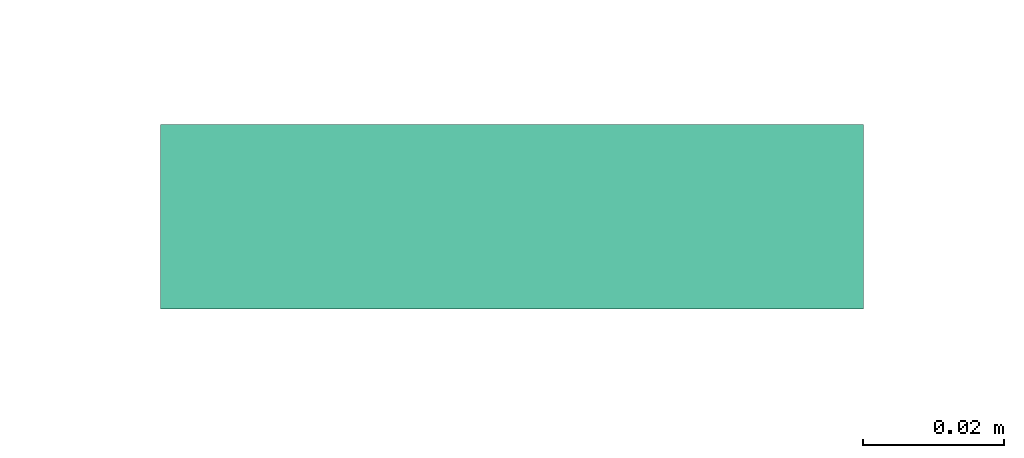
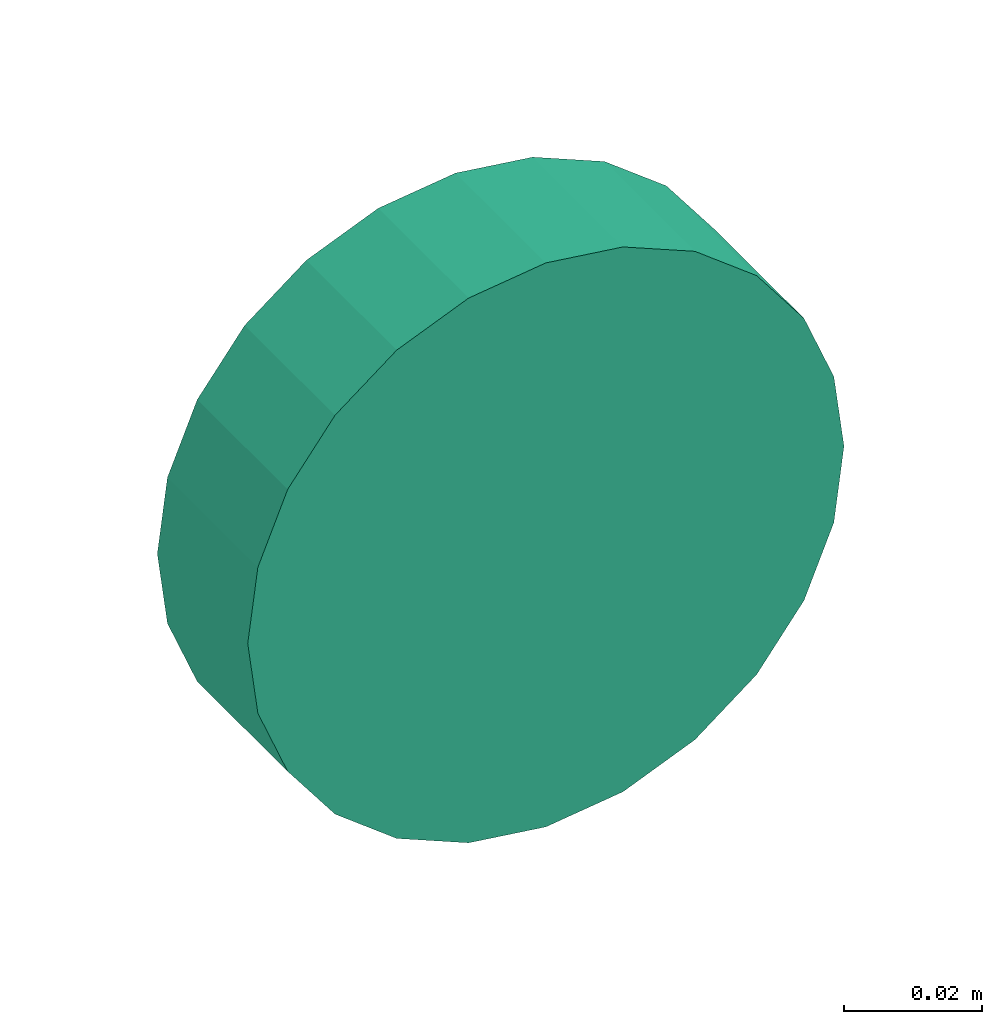
# One storey, part 30 of 32: 1 flow fitting.
"""IFC2X3 building model written with IfcOpenShell, lengths in millimetres."""

from ifc_helpers import new_model, entity, si_unit, converted_unit, derived_unit, direction, frame, origin, place, context, subcontext, project, spatial, faceted_brep, source, transform, mapped, material, type_object, type_shapes, element, save


model = new_model("IFC2X3")

# Units and contexts
model_context = context("Model", 3, precision=0.01, world=origin(), true_north=direction((6.12303176911189e-17, 1.0)))
body_context = subcontext(model_context, "Body", "Model", "MODEL_VIEW")
ifc_project = project(units=[si_unit("LENGTHUNIT", "METRE", prefix="MILLI"), si_unit("AREAUNIT", "SQUARE_METRE"), si_unit("VOLUMEUNIT", "CUBIC_METRE"), converted_unit("PLANEANGLEUNIT", "DEGREE", entity("IfcRatioMeasure", 0.0174532925199433), si_unit("PLANEANGLEUNIT", "RADIAN"), dimensions=[0, 0, 0, 0, 0, 0, 0]), si_unit("MASSUNIT", "GRAM", prefix="KILO"), derived_unit("MASSDENSITYUNIT", [(si_unit("MASSUNIT", "GRAM", prefix="KILO"), 1), (si_unit("LENGTHUNIT", "METRE"), -3)]), derived_unit("MOMENTOFINERTIAUNIT", [(si_unit("LENGTHUNIT", "METRE"), 4)]), si_unit("TIMEUNIT", "SECOND"), si_unit("FREQUENCYUNIT", "HERTZ"), si_unit("THERMODYNAMICTEMPERATUREUNIT", "DEGREE_CELSIUS"), derived_unit("THERMALTRANSMITTANCEUNIT", [(si_unit("MASSUNIT", "GRAM", prefix="KILO"), 1), (si_unit("THERMODYNAMICTEMPERATUREUNIT", "KELVIN"), -1), (si_unit("TIMEUNIT", "SECOND"), -3)]), derived_unit("VOLUMETRICFLOWRATEUNIT", [(si_unit("LENGTHUNIT", "METRE"), 3), (si_unit("TIMEUNIT", "SECOND"), -1)]), derived_unit("MASSFLOWRATEUNIT", [(si_unit("MASSUNIT", "GRAM", prefix="KILO"), 1), (si_unit("TIMEUNIT", "SECOND"), -1)]), derived_unit("ROTATIONALFREQUENCYUNIT", [(si_unit("TIMEUNIT", "SECOND"), -1)]), si_unit("ELECTRICCURRENTUNIT", "AMPERE"), si_unit("ELECTRICVOLTAGEUNIT", "VOLT"), si_unit("POWERUNIT", "WATT"), si_unit("FORCEUNIT", "NEWTON", prefix="KILO"), si_unit("ILLUMINANCEUNIT", "LUX"), si_unit("LUMINOUSFLUXUNIT", "LUMEN"), si_unit("LUMINOUSINTENSITYUNIT", "CANDELA"), derived_unit("USERDEFINED", [(si_unit("MASSUNIT", "GRAM", prefix="KILO"), -1), (si_unit("LENGTHUNIT", "METRE"), -2), (si_unit("TIMEUNIT", "SECOND"), 3), (si_unit("LUMINOUSFLUXUNIT", "LUMEN"), 1)]), derived_unit("LINEARVELOCITYUNIT", [(si_unit("LENGTHUNIT", "METRE"), 1), (si_unit("TIMEUNIT", "SECOND"), -1)]), si_unit("PRESSUREUNIT", "PASCAL"), derived_unit("USERDEFINED", [(si_unit("LENGTHUNIT", "METRE"), -2), (si_unit("MASSUNIT", "GRAM", prefix="KILO"), 1), (si_unit("TIMEUNIT", "SECOND"), -2)]), derived_unit("LINEARFORCEUNIT", [(si_unit("MASSUNIT", "GRAM", prefix="KILO"), 1), (si_unit("LENGTHUNIT", "METRE"), 1), (si_unit("TIMEUNIT", "SECOND"), -2), (si_unit("LENGTHUNIT", "METRE"), -1)]), derived_unit("PLANARFORCEUNIT", [(si_unit("MASSUNIT", "GRAM", prefix="KILO"), 1), (si_unit("LENGTHUNIT", "METRE"), 1), (si_unit("TIMEUNIT", "SECOND"), -2), (si_unit("LENGTHUNIT", "METRE"), -2)])], contexts=[model_context])

# Site, building, storey
site_placement = place(None, origin())
site = spatial("IfcSite", under=ifc_project, at=site_placement, CompositionType="ELEMENT")
building_placement = place(site_placement, origin())
building = spatial("IfcBuilding", under=site, at=building_placement, CompositionType="ELEMENT")
storey_placement = place(building_placement, frame((0.0, 0.0, 8100.0)))
storey = spatial("IfcBuildingStorey", under=building, at=storey_placement, CompositionType="ELEMENT", Elevation=8100.0)

# Flow fitting
ifc_material = material()
duct_fitting_type = type_object("IfcDuctFittingType", PredefinedType="NOTDEFINED", material=ifc_material)
shared_shape = source(origin(), body_context, "Body", "Brep", [
    faceted_brep([(20.08, 12.94, -48.3), (20.08, 25.0, -43.3), (20.08, 35.36, -35.36), (20.08, 43.3, -25.0), (20.08, 48.3, -12.94), (20.08, 50.0, 0.0), (20.08, 48.3, 12.94), (20.08, 43.3, 25.0), (20.08, 35.36, 35.36), (20.08, 25.0, 43.3), (20.08, 12.94, 48.3), (20.08, 0.0, 50.0), (20.08, -12.94, 48.3), (20.08, -25.0, 43.3), (20.08, -35.36, 35.36), (20.08, -43.3, 25.0), (20.08, -48.3, 12.94), (20.08, -50.0, 0.0), (20.08, -48.3, -12.94), (20.08, -43.3, -25.0), (20.08, -35.36, -35.36), (20.08, -25.0, -43.3), (20.08, -12.94, -48.3), (20.08, 0.0, -50.0), (0.0, 0.0, 50.0), (0.0, 12.94, 48.3), (-6.18, 12.94, 48.3), (-6.18, 0.0, 50.0), (0.0, 25.0, 43.3), (-6.18, 25.0, 43.3), (0.0, 35.36, 35.36), (-6.18, 35.36, 35.36), (0.0, 43.3, 25.0), (0.0, 48.3, 12.94), (-6.18, 48.3, 12.94), (-6.18, 43.3, 25.0), (0.0, 50.0, 0.0), (-6.18, 50.0, 0.0), (0.0, 48.3, -12.94), (-6.18, 48.3, -12.94), (0.0, 43.3, -25.0), (-6.18, 43.3, -25.0), (0.0, 35.36, -35.36), (-6.18, 35.36, -35.36), (0.0, 25.0, -43.3), (0.0, 12.94, -48.3), (-6.18, 12.94, -48.3), (-6.18, 25.0, -43.3), (0.0, 0.0, -50.0), (-6.18, 0.0, -50.0), (0.0, -12.94, -48.3), (-6.18, -12.94, -48.3), (0.0, -25.0, -43.3), (-6.18, -25.0, -43.3), (0.0, -35.36, -35.36), (-6.18, -35.36, -35.36), (0.0, -43.3, -25.0), (0.0, -48.3, -12.94), (-6.18, -48.3, -12.94), (-6.18, -43.3, -25.0), (0.0, -50.0, 0.0), (-6.18, -50.0, 0.0), (0.0, -48.3, 12.94), (-6.18, -48.3, 12.94), (0.0, -43.3, 25.0), (-6.18, -43.3, 25.0), (0.0, -35.36, 35.36), (-6.18, -35.36, 35.36), (0.0, -25.0, 43.3), (0.0, -12.94, 48.3), (-6.18, -12.94, 48.3), (-6.18, -25.0, 43.3)], [[[0, 1, 2, 3, 4, 5, 6, 7, 8, 9, 10, 11, 12, 13, 14, 15, 16, 17, 18, 19, 20, 21, 22, 23]], [[24, 11, 10, 25, 26, 27]], [[25, 10, 9, 28, 29, 26]], [[28, 9, 8, 30, 31, 29]], [[32, 7, 6, 33, 34, 35]], [[33, 6, 5, 36, 37, 34]], [[30, 8, 7, 32, 35, 31]], [[36, 5, 4, 38, 39, 37]], [[38, 4, 3, 40, 41, 39]], [[40, 3, 2, 42, 43, 41]], [[44, 1, 0, 45, 46, 47]], [[45, 0, 23, 48, 49, 46]], [[42, 2, 1, 44, 47, 43]], [[48, 23, 22, 50, 51, 49]], [[50, 22, 21, 52, 53, 51]], [[52, 21, 20, 54, 55, 53]], [[56, 19, 18, 57, 58, 59]], [[57, 18, 17, 60, 61, 58]], [[54, 20, 19, 56, 59, 55]], [[60, 17, 16, 62, 63, 61]], [[62, 16, 15, 64, 65, 63]], [[64, 15, 14, 66, 67, 65]], [[68, 13, 12, 69, 70, 71]], [[69, 12, 11, 24, 27, 70]], [[66, 14, 13, 68, 71, 67]], [[49, 51, 53, 55, 59, 58, 61, 63, 65, 67, 71, 70, 27, 26, 29, 31, 35, 34, 37, 39, 41, 43, 47, 46]]]),
])
type_shapes(duct_fitting_type, [shared_shape])
flow_fitting_placement = place(storey_placement, frame((25148.81, 17270.98, 3200.0), z_axis=(0.0, 0.0, -1.0), x_axis=(0.0, -1.0, 0.0)))
element("IfcFlowFitting", 1, at=flow_fitting_placement, inside=storey, type_object=duct_fitting_type, material=ifc_material, context=body_context, shape_type="MappedRepresentation", body=[
    mapped(shared_shape, transform((0.0, 0.0, 0.0), scale=1.0)),
])

save(model, "model.ifc")
